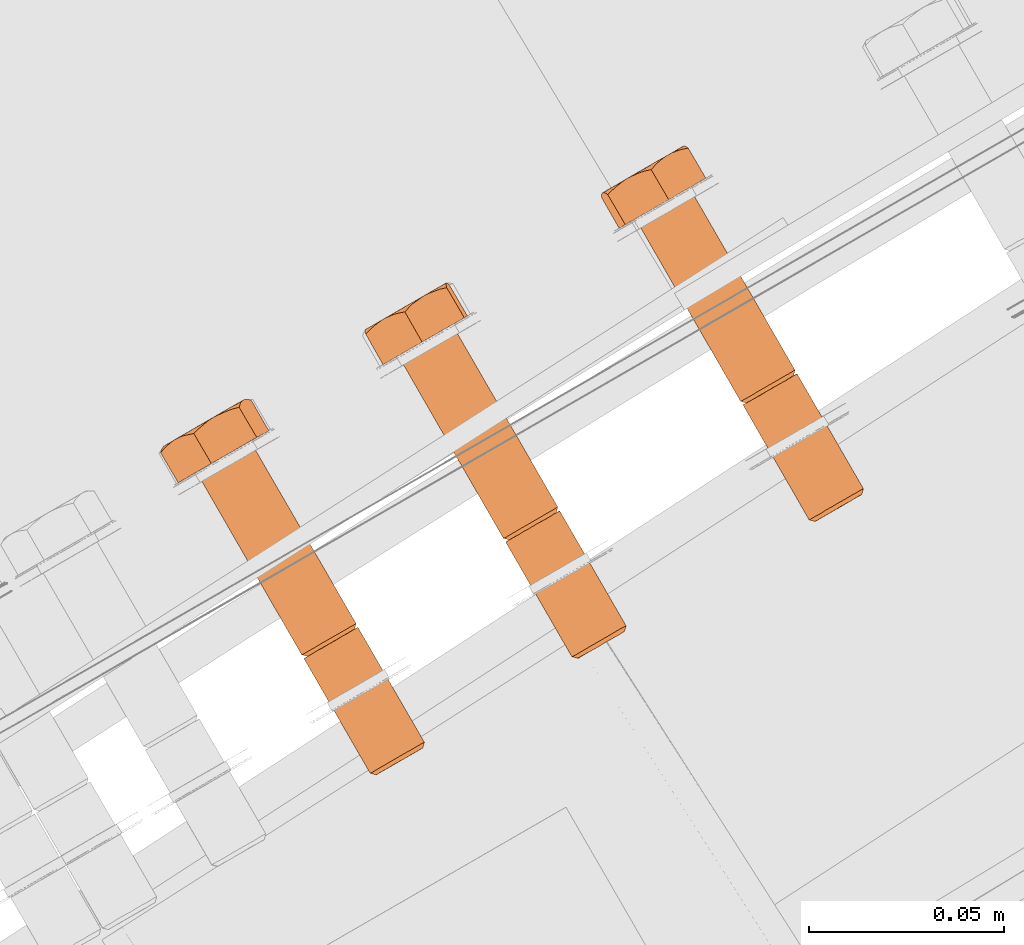
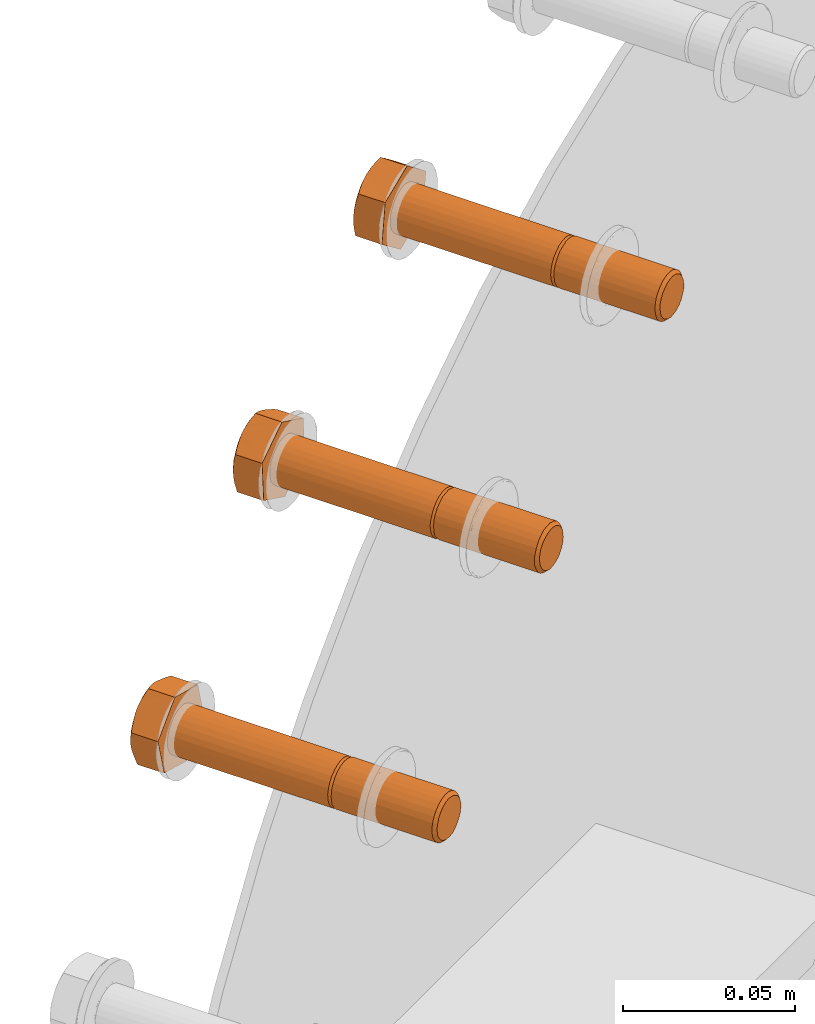
# One storey, part 72 of 126: 3 proxies.
"""IFC2X3 building model written with IfcOpenShell, lengths in millimetres."""

from ifc_helpers import new_model, si_unit, origin, origin_with_axes, place, context, project, spatial, faceted_brep, material, element, save


model = new_model("IFC2X3")

# Units and contexts
context_of_model_1 = context(None, 3, precision=0.1, world=origin())
context_of_model_2 = context(None, 3, precision=0.1, world=origin())
ifc_project = project(units=[si_unit("LENGTHUNIT", "METRE", prefix="MILLI"), si_unit("AREAUNIT", "SQUARE_METRE", prefix="CENTI"), si_unit("VOLUMEUNIT", "CUBIC_METRE", prefix="CENTI"), si_unit("MASSUNIT", "GRAM", prefix="KILO")], contexts=[context_of_model_1, context_of_model_2])

# Site, building, storey
site_placement = place(None, origin_with_axes())
site = spatial("IfcSite", under=ifc_project, at=site_placement, CompositionType="ELEMENT")
building_placement = place(site_placement, origin_with_axes())
building = spatial("IfcBuilding", under=site, at=building_placement, CompositionType="ELEMENT")
storey_placement = place(building_placement, origin_with_axes())
storey = spatial("IfcBuildingStorey", under=building, at=storey_placement, CompositionType="ELEMENT")

# Proxies
ifc_material = material(Name="STAHL")
proxy_1_placement = place(storey_placement, origin_with_axes())
element("IfcBuildingElementProxy", 1, at=proxy_1_placement, inside=storey, material=ifc_material, Name="profile", context=context_of_model_2, shape_type="Brep", body=[
    faceted_brep([(3737.7, 14723.2, 1175.6), (3736.3, 14722.4, 1174.4), (3737.6, 14721.9, 1173.7), (3738.7, 14722.5, 1174.7), (3740.0, 14723.3, 1175.4), (3739.2, 14724.1, 1176.4), (3741.4, 14724.1, 1175.7), (3740.8, 14725.0, 1176.8), (3742.9, 14724.9, 1175.6), (3742.5, 14726.0, 1176.7), (3744.2, 14725.7, 1175.1), (3744.1, 14726.9, 1176.1), (3745.5, 14726.4, 1174.2), (3745.5, 14727.7, 1175.1), (3746.5, 14727.0, 1173.1), (3746.7, 14728.4, 1173.7), (3747.3, 14727.5, 1171.6), (3747.6, 14728.9, 1172.1), (3747.7, 14727.7, 1170.0), (3748.1, 14729.2, 1170.2), (3747.8, 14727.8, 1168.4), (3748.2, 14729.2, 1168.3), (3747.5, 14727.6, 1166.7), (3747.9, 14729.1, 1166.4), (3746.9, 14727.3, 1165.2), (3747.2, 14728.7, 1164.7), (3746.0, 14726.8, 1163.9), (3746.1, 14728.1, 1163.1), (3721.2, 14752.8, 1174.7), (3720.2, 14753.5, 1175.6), (3718.8, 14752.7, 1174.4), (3720.1, 14752.2, 1173.7), (3722.5, 14753.6, 1175.4), (3721.7, 14754.4, 1176.4), (3723.9, 14754.4, 1175.7), (3723.3, 14755.3, 1176.8), (3725.4, 14755.2, 1175.6), (3725.0, 14756.3, 1176.7), (3726.7, 14756.0, 1175.1), (3726.6, 14757.2, 1176.1), (3728.0, 14756.8, 1174.2), (3728.0, 14758.0, 1175.1), (3729.0, 14757.3, 1173.1), (3729.2, 14758.7, 1173.7), (3729.8, 14757.8, 1171.6), (3730.1, 14759.2, 1172.1), (3730.2, 14758.0, 1170.0), (3730.6, 14759.5, 1170.2), (3730.3, 14758.1, 1168.4), (3730.7, 14759.6, 1168.3), (3730.0, 14757.9, 1166.7), (3730.4, 14759.4, 1166.4), (3729.4, 14757.6, 1165.2), (3729.7, 14759.0, 1164.7), (3728.5, 14757.1, 1163.9), (3728.6, 14758.4, 1163.1), (3719.4, 14751.8, 1174.4), (3718.4, 14751.2, 1172.9), (3735.3, 14721.8, 1172.9), (3744.8, 14727.3, 1161.9), (3727.9, 14756.7, 1161.9), (3729.2, 14757.5, 1163.1), (3743.3, 14726.4, 1161.2), (3726.3, 14755.8, 1161.2), (3741.7, 14725.5, 1160.8), (3724.7, 14754.9, 1160.8), (3740.0, 14724.5, 1160.9), (3723.0, 14753.9, 1160.9), (3738.4, 14723.6, 1161.5), (3721.4, 14753.0, 1161.5), (3737.0, 14722.8, 1162.5), (3720.0, 14752.2, 1162.5), (3735.8, 14722.1, 1163.9), (3718.8, 14751.5, 1163.9), (3734.9, 14721.6, 1165.5), (3718.0, 14751.0, 1165.5), (3734.4, 14721.3, 1167.3), (3717.5, 14750.7, 1167.3), (3734.3, 14721.3, 1169.3), (3717.4, 14750.6, 1169.3), (3734.6, 14721.4, 1171.2), (3717.7, 14750.8, 1171.2), (3693.2, 14800.2, 1175.6), (3691.9, 14799.4, 1174.4), (3694.7, 14801.1, 1176.4), (3696.4, 14802.0, 1176.8), (3698.0, 14803.0, 1176.7), (3699.6, 14803.9, 1176.1), (3701.1, 14804.7, 1175.1), (3702.2, 14805.4, 1173.7), (3703.1, 14805.9, 1172.1), (3703.6, 14806.2, 1170.2), (3703.7, 14806.2, 1168.3), (3703.4, 14806.1, 1166.4), (3702.7, 14805.7, 1164.7), (3701.7, 14805.1, 1163.1), (3717.8, 14752.1, 1172.9), (3690.9, 14798.8, 1172.9), (3690.2, 14798.4, 1171.2), (3717.1, 14751.7, 1171.2), (3727.3, 14757.6, 1161.9), (3700.4, 14804.3, 1161.9), (3725.8, 14756.7, 1161.2), (3698.8, 14803.4, 1161.2), (3724.2, 14755.8, 1160.8), (3697.2, 14802.5, 1160.8), (3722.5, 14754.8, 1160.9), (3695.5, 14801.5, 1160.9), (3720.9, 14753.9, 1161.5), (3693.9, 14800.6, 1161.5), (3719.5, 14753.1, 1162.5), (3692.5, 14799.8, 1162.5), (3718.3, 14752.4, 1163.9), (3691.3, 14799.1, 1163.9), (3717.4, 14751.9, 1165.5), (3690.5, 14798.6, 1165.5), (3716.9, 14751.6, 1167.3), (3690.0, 14798.3, 1167.3), (3716.8, 14751.6, 1169.3), (3689.9, 14798.3, 1169.3), (3685.2, 14795.6, 1172.4), (3688.3, 14797.4, 1159.0), (3699.9, 14804.0, 1155.4), (3708.4, 14808.9, 1165.2), (3705.3, 14807.2, 1178.6), (3693.7, 14800.5, 1182.2), (3683.8, 14805.1, 1159.0), (3685.3, 14806.5, 1158.5), (3686.7, 14807.7, 1158.0), (3687.9, 14808.6, 1157.6), (3689.1, 14809.4, 1157.2), (3690.7, 14810.2, 1156.7), (3692.4, 14810.9, 1156.2), (3693.9, 14811.4, 1155.8), (3695.4, 14811.8, 1155.4), (3690.9, 14810.4, 1156.8), (3692.7, 14811.4, 1156.8), (3694.5, 14812.5, 1157.2), (3696.2, 14813.4, 1157.9), (3697.7, 14814.4, 1159.0), (3698.2, 14814.6, 1159.2), (3697.4, 14813.9, 1158.2), (3696.4, 14812.9, 1156.8), (3699.1, 14815.2, 1160.3), (3681.7, 14805.1, 1165.7), (3682.4, 14805.5, 1163.7), (3683.3, 14806.0, 1161.9), (3684.4, 14806.7, 1160.3), (3685.8, 14807.5, 1159.0), (3687.4, 14808.4, 1157.9), (3683.3, 14805.2, 1160.5), (3682.8, 14805.3, 1162.0), (3682.2, 14805.3, 1163.9), (3680.7, 14803.3, 1172.4), (3681.5, 14804.2, 1173.5), (3682.3, 14805.0, 1174.6), (3683.3, 14805.9, 1175.9), (3684.4, 14806.7, 1177.3), (3683.3, 14806.0, 1175.7), (3682.4, 14805.5, 1173.9), (3681.7, 14805.1, 1171.9), (3681.4, 14804.9, 1169.8), (3681.4, 14804.9, 1167.7), (3681.4, 14804.9, 1167.1), (3681.2, 14804.5, 1168.6), (3680.9, 14804.0, 1170.5), (3700.3, 14815.8, 1161.6), (3701.6, 14816.2, 1163.0), (3702.7, 14816.5, 1164.1), (3703.9, 14816.7, 1165.2), (3703.2, 14816.9, 1167.1), (3702.6, 14816.9, 1169.0), (3702.2, 14816.9, 1170.4), (3701.8, 14816.7, 1171.9), (3701.4, 14816.4, 1173.7), (3701.1, 14815.9, 1175.5), (3701.0, 14815.5, 1177.0), (3700.8, 14814.9, 1178.6), (3685.4, 14807.2, 1178.4), (3686.4, 14807.6, 1179.4), (3687.8, 14807.9, 1180.8), (3689.2, 14808.2, 1182.2), (3690.3, 14809.3, 1181.8), (3691.5, 14810.3, 1181.4), (3692.9, 14811.5, 1180.9), (3694.5, 14812.5, 1180.4), (3692.7, 14811.4, 1180.7), (3690.9, 14810.4, 1180.7), (3689.1, 14809.4, 1180.4), (3687.4, 14808.4, 1179.7), (3685.8, 14807.5, 1178.6), (3696.2, 14813.4, 1179.7), (3697.1, 14813.7, 1179.6), (3698.9, 14814.4, 1179.1), (3701.2, 14816.4, 1173.9), (3700.3, 14815.8, 1175.7), (3699.1, 14815.2, 1177.3), (3697.7, 14814.4, 1178.6), (3695.8, 14813.1, 1180.0), (3700.3, 14815.8, 1161.9), (3701.2, 14816.4, 1163.7), (3701.8, 14816.7, 1165.7), (3702.1, 14816.9, 1167.7), (3702.1, 14816.9, 1169.8), (3720.7, 14752.6, 1175.6), (3719.2, 14751.7, 1172.4), (3718.6, 14751.3, 1170.8), (3718.3, 14751.2, 1169.2), (3718.4, 14751.2, 1167.5), (3718.8, 14751.5, 1165.9), (3719.6, 14751.9, 1164.5), (3720.6, 14752.5, 1163.3), (3721.8, 14753.2, 1162.5), (3723.2, 14754.0, 1162.0), (3724.6, 14754.8, 1161.9), (3726.1, 14755.7, 1162.2), (3727.4, 14756.4, 1162.9), (3722.2, 14753.4, 1176.4), (3723.9, 14754.4, 1176.8), (3725.5, 14755.3, 1176.7), (3727.1, 14756.3, 1176.1), (3728.6, 14757.1, 1175.1), (3729.7, 14757.8, 1173.7), (3730.6, 14758.3, 1172.1), (3731.1, 14758.6, 1170.2), (3731.2, 14758.6, 1168.3), (3730.9, 14758.4, 1166.4), (3730.2, 14758.0, 1164.7), (3735.8, 14720.9, 1169.2), (3735.9, 14720.9, 1167.5), (3736.3, 14721.2, 1165.9), (3737.1, 14721.6, 1164.5), (3738.1, 14722.2, 1163.3), (3739.3, 14722.9, 1162.5), (3740.7, 14723.7, 1162.0), (3742.1, 14724.5, 1161.9), (3743.6, 14725.3, 1162.2), (3744.9, 14726.1, 1162.9), (3736.7, 14721.4, 1172.4), (3736.1, 14721.0, 1170.8)], [[[0, 1, 2, 3]], [[4, 5, 0, 3]], [[6, 7, 5, 4]], [[8, 9, 7, 6]], [[10, 11, 9, 8]], [[12, 13, 11, 10]], [[14, 15, 13, 12]], [[16, 17, 15, 14]], [[18, 19, 17, 16]], [[20, 21, 19, 18]], [[22, 23, 21, 20]], [[24, 25, 23, 22]], [[26, 27, 25, 24]], [[28, 29, 30, 31]], [[32, 33, 29, 28]], [[34, 35, 33, 32]], [[36, 37, 35, 34]], [[38, 39, 37, 36]], [[40, 41, 39, 38]], [[42, 43, 41, 40]], [[44, 45, 43, 42]], [[46, 47, 45, 44]], [[48, 49, 47, 46]], [[50, 51, 49, 48]], [[52, 53, 51, 50]], [[54, 55, 53, 52]], [[1, 56, 57, 58]], [[59, 60, 61, 27]], [[62, 63, 60, 59]], [[64, 65, 63, 62]], [[66, 67, 65, 64]], [[68, 69, 67, 66]], [[70, 71, 69, 68]], [[72, 73, 71, 70]], [[74, 75, 73, 72]], [[76, 77, 75, 74]], [[78, 79, 77, 76]], [[80, 81, 79, 78]], [[58, 57, 81, 80]], [[29, 82, 83, 30]], [[29, 33, 84, 82]], [[33, 35, 85, 84]], [[35, 37, 86, 85]], [[37, 39, 87, 86]], [[39, 41, 88, 87]], [[41, 43, 89, 88]], [[43, 45, 90, 89]], [[45, 47, 91, 90]], [[47, 49, 92, 91]], [[49, 51, 93, 92]], [[51, 53, 94, 93]], [[55, 95, 94, 53]], [[96, 97, 98, 99]], [[30, 83, 97, 96]], [[55, 100, 101, 95]], [[102, 103, 101, 100]], [[104, 105, 103, 102]], [[106, 107, 105, 104]], [[108, 109, 107, 106]], [[110, 111, 109, 108]], [[112, 113, 111, 110]], [[114, 115, 113, 112]], [[116, 117, 115, 114]], [[118, 119, 117, 116]], [[99, 98, 119, 118]], [[120, 121, 122, 123, 124, 125, 86, 87, 88, 89, 90, 91, 92, 93, 94, 95, 101, 103, 105, 107, 109, 111, 113, 115, 117, 119, 98, 97, 83, 82, 84, 85, 86, 125]], [[121, 126, 127, 128, 129, 130, 131, 132, 133, 134, 122]], [[130, 135, 136, 137, 138, 139, 140, 141, 142, 134, 133, 132, 131]], [[143, 140, 139]], [[144, 145, 146, 147, 148, 149, 129, 128, 127, 126, 150, 151, 152]], [[130, 129, 149]], [[153, 154, 155, 156, 157, 158, 159, 160, 161, 162, 163, 164, 165]], [[144, 163, 162]], [[122, 134, 142, 141, 140, 143, 166, 167, 168, 169, 123]], [[124, 123, 169, 170, 171, 172, 173, 174, 175, 176, 177]], [[178, 179, 180, 181, 182, 183, 184, 185, 186, 187, 188, 189, 190]], [[157, 178, 190]], [[191, 192, 193, 177, 176, 175, 174, 173, 194, 195, 196, 197]], [[198, 192, 191]], [[185, 198, 191]], [[143, 199, 200, 201, 202, 203, 172, 171, 170, 169, 168, 167, 166]], [[173, 172, 203]], [[125, 124, 177, 193, 192, 198, 185, 184, 183, 182, 181]], [[120, 125, 181, 180, 179, 178, 157, 156, 155, 154, 153]], [[120, 153, 165, 164, 163, 144, 152, 151, 150, 126, 121]], [[161, 160, 159, 158, 157, 190, 189, 188, 187, 186, 185, 191, 197, 196, 195, 194, 173, 203, 202, 201, 200, 199, 143, 139, 138, 137, 136, 135, 130, 149, 148, 147, 146, 145, 144, 162]], [[79, 81, 57, 56, 204, 28, 31, 205, 206, 207, 208, 209, 210, 211, 212, 213, 214, 215, 216, 54, 52, 50, 48, 46, 44, 42, 40, 38, 36, 34, 32, 28, 204, 217, 218, 219, 220, 221, 222, 223, 224, 225, 226, 227, 61, 60, 63, 65, 67, 69, 71, 73, 75, 77]], [[100, 55, 54, 216]], [[102, 100, 216, 215]], [[104, 102, 215, 214]], [[106, 104, 214, 213]], [[108, 106, 213, 212]], [[110, 108, 212, 211]], [[112, 110, 211, 210]], [[114, 112, 210, 209]], [[116, 114, 209, 208]], [[118, 116, 208, 207]], [[99, 118, 207, 206]], [[96, 99, 206, 205]], [[31, 30, 96, 205]], [[0, 204, 56, 1]], [[0, 5, 217, 204]], [[5, 7, 218, 217]], [[7, 9, 219, 218]], [[9, 11, 220, 219]], [[11, 13, 221, 220]], [[13, 15, 222, 221]], [[15, 17, 223, 222]], [[17, 19, 224, 223]], [[19, 21, 225, 224]], [[21, 23, 226, 225]], [[23, 25, 227, 226]], [[25, 27, 61, 227]], [[228, 229, 230, 231, 232, 233, 234, 235, 236, 237, 26, 24, 22, 20, 18, 16, 14, 12, 10, 8, 6, 4, 3, 2, 238, 239]], [[237, 59, 27, 26]], [[236, 62, 59, 237]], [[235, 64, 62, 236]], [[234, 66, 64, 235]], [[233, 68, 66, 234]], [[232, 70, 68, 233]], [[231, 72, 70, 232]], [[230, 74, 72, 231]], [[229, 76, 74, 230]], [[228, 78, 76, 229]], [[239, 80, 78, 228]], [[238, 58, 80, 239]], [[2, 1, 58, 238]]]),
])
proxy_2_placement = place(storey_placement, origin_with_axes())
element("IfcBuildingElementProxy", 2, at=proxy_2_placement, inside=storey, material=ifc_material, Name="profile", context=context_of_model_2, shape_type="Brep", body=[
    faceted_brep([(3791.4, 14752.9, 1234.9), (3790.5, 14753.7, 1235.9), (3789.0, 14752.8, 1235.0), (3790.1, 14752.2, 1234.1), (3792.1, 14754.6, 1236.3), (3792.8, 14753.7, 1235.3), (3793.8, 14755.6, 1236.3), (3794.2, 14754.6, 1235.2), (3795.4, 14756.5, 1235.8), (3795.6, 14755.4, 1234.8), (3796.9, 14757.4, 1234.9), (3796.9, 14756.1, 1234.0), (3798.1, 14758.1, 1233.6), (3798.0, 14756.7, 1232.9), (3799.0, 14758.6, 1232.0), (3798.8, 14757.2, 1231.5), (3799.6, 14758.9, 1230.2), (3799.2, 14757.5, 1229.9), (3799.8, 14759.0, 1228.3), (3799.4, 14757.6, 1228.3), (3799.6, 14758.9, 1226.4), (3799.2, 14757.5, 1226.6), (3799.0, 14758.6, 1224.6), (3798.7, 14757.2, 1225.1), (3798.0, 14758.0, 1223.0), (3797.8, 14756.7, 1223.7), (3796.7, 14757.3, 1221.7), (3796.7, 14756.0, 1222.6), (3773.9, 14783.2, 1234.9), (3773.0, 14784.0, 1235.9), (3771.5, 14783.1, 1235.0), (3772.6, 14782.5, 1234.1), (3775.3, 14784.1, 1235.3), (3774.6, 14784.9, 1236.3), (3776.7, 14784.9, 1235.2), (3776.3, 14785.9, 1236.3), (3778.1, 14785.7, 1234.8), (3777.9, 14786.8, 1235.8), (3779.4, 14786.4, 1234.0), (3779.4, 14787.7, 1234.9), (3780.5, 14787.0, 1232.9), (3780.6, 14788.4, 1233.6), (3781.3, 14787.5, 1231.5), (3781.5, 14788.9, 1232.0), (3781.7, 14787.8, 1229.9), (3782.1, 14789.3, 1230.2), (3781.9, 14787.9, 1228.3), (3782.3, 14789.4, 1228.3), (3781.7, 14787.8, 1226.6), (3782.1, 14789.2, 1226.4), (3781.2, 14787.5, 1225.1), (3781.5, 14788.9, 1224.6), (3780.3, 14787.0, 1223.7), (3780.5, 14788.3, 1223.0), (3779.2, 14786.3, 1222.6), (3779.2, 14787.6, 1221.7), (3772.1, 14782.2, 1235.0), (3770.8, 14781.5, 1233.8), (3787.8, 14752.1, 1233.8), (3795.2, 14756.4, 1220.9), (3778.3, 14785.8, 1220.9), (3779.8, 14786.6, 1221.7), (3793.6, 14755.5, 1220.4), (3776.6, 14784.8, 1220.4), (3791.9, 14754.5, 1220.5), (3775.0, 14783.9, 1220.5), (3790.3, 14753.6, 1221.0), (3773.4, 14782.9, 1221.0), (3788.8, 14752.7, 1221.9), (3771.9, 14782.1, 1221.9), (3787.6, 14752.0, 1223.2), (3770.7, 14781.4, 1223.2), (3786.7, 14751.5, 1224.8), (3769.7, 14780.9, 1224.8), (3786.1, 14751.2, 1226.6), (3769.2, 14780.5, 1226.6), (3785.9, 14751.1, 1228.5), (3769.0, 14780.4, 1228.5), (3786.2, 14751.2, 1230.4), (3769.2, 14780.6, 1230.4), (3786.8, 14751.5, 1232.2), (3769.8, 14780.9, 1232.2), (3746.0, 14830.7, 1235.9), (3744.6, 14829.8, 1235.0), (3747.7, 14831.6, 1236.3), (3749.3, 14832.6, 1236.3), (3751.0, 14833.5, 1235.8), (3752.4, 14834.4, 1234.9), (3753.7, 14835.1, 1233.6), (3754.6, 14835.6, 1232.0), (3755.2, 14836.0, 1230.2), (3755.3, 14836.1, 1228.3), (3755.1, 14835.9, 1226.4), (3754.5, 14835.6, 1224.6), (3753.5, 14835.0, 1223.0), (3752.3, 14834.3, 1221.7), (3770.3, 14782.4, 1233.8), (3743.3, 14829.1, 1233.8), (3742.3, 14828.5, 1232.2), (3769.3, 14781.8, 1232.2), (3777.7, 14786.7, 1220.9), (3750.8, 14833.4, 1220.9), (3776.1, 14785.8, 1220.4), (3749.1, 14832.5, 1220.4), (3774.4, 14784.8, 1220.5), (3747.5, 14831.5, 1220.5), (3772.8, 14783.9, 1221.0), (3745.9, 14830.6, 1221.0), (3771.3, 14783.0, 1221.9), (3744.4, 14829.7, 1221.9), (3770.1, 14782.3, 1223.2), (3743.2, 14829.0, 1223.2), (3769.2, 14781.8, 1224.8), (3742.2, 14828.5, 1224.8), (3768.6, 14781.5, 1226.6), (3741.7, 14828.2, 1226.6), (3768.4, 14781.4, 1228.5), (3741.5, 14828.1, 1228.5), (3768.7, 14781.5, 1230.4), (3741.7, 14828.2, 1230.4), (3737.6, 14825.8, 1234.5), (3738.4, 14826.3, 1220.7), (3749.2, 14832.5, 1214.6), (3759.2, 14838.3, 1222.3), (3758.4, 14837.8, 1236.1), (3747.6, 14831.6, 1242.2), (3734.0, 14834.0, 1220.7), (3735.3, 14835.4, 1219.8), (3736.6, 14836.5, 1219.0), (3737.7, 14837.3, 1218.3), (3738.8, 14838.1, 1217.6), (3740.3, 14838.8, 1216.8), (3741.9, 14839.5, 1216.0), (3743.3, 14839.9, 1215.3), (3744.7, 14840.2, 1214.6), (3740.5, 14839.0, 1216.9), (3742.3, 14840.1, 1216.5), (3744.1, 14841.1, 1216.4), (3745.9, 14842.1, 1216.7), (3747.6, 14843.1, 1217.4), (3748.1, 14843.4, 1217.6), (3747.1, 14842.6, 1216.7), (3745.9, 14841.5, 1215.7), (3749.2, 14844.0, 1218.4), (3733.7, 14834.3, 1222.3), (3733.4, 14834.6, 1223.8), (3733.2, 14834.7, 1225.7), (3733.0, 14834.7, 1227.6), (3733.3, 14834.9, 1225.5), (3733.9, 14835.2, 1223.6), (3734.8, 14835.7, 1221.7), (3735.9, 14836.4, 1220.1), (3737.3, 14837.2, 1218.7), (3733.2, 14833.6, 1234.5), (3734.1, 14834.6, 1235.4), (3735.1, 14835.5, 1236.3), (3736.3, 14836.5, 1237.3), (3737.6, 14837.4, 1238.4), (3736.2, 14836.6, 1237.1), (3735.0, 14835.9, 1235.5), (3734.1, 14835.3, 1233.7), (3733.4, 14835.0, 1231.8), (3733.1, 14834.8, 1229.7), (3733.0, 14834.4, 1230.6), (3733.0, 14834.1, 1232.5), (3733.0, 14834.6, 1229.1), (3750.6, 14844.8, 1219.5), (3752.1, 14845.3, 1220.5), (3753.4, 14845.7, 1221.4), (3754.7, 14846.0, 1222.3), (3754.3, 14846.4, 1224.3), (3754.1, 14846.6, 1226.2), (3753.9, 14846.7, 1227.7), (3753.8, 14846.7, 1229.2), (3753.7, 14846.6, 1231.1), (3753.7, 14846.3, 1233.0), (3753.8, 14846.0, 1234.5), (3753.9, 14845.5, 1236.1), (3738.8, 14838.0, 1239.2), (3739.9, 14838.5, 1240.1), (3741.5, 14839.0, 1241.1), (3743.2, 14839.3, 1242.2), (3744.2, 14840.4, 1241.5), (3745.2, 14841.4, 1240.8), (3746.6, 14842.4, 1240.0), (3748.0, 14843.4, 1239.2), (3746.3, 14842.4, 1239.9), (3744.5, 14841.4, 1240.3), (3742.7, 14840.3, 1240.4), (3740.9, 14839.3, 1240.1), (3739.2, 14838.3, 1239.4), (3749.2, 14844.0, 1238.5), (3750.5, 14844.5, 1237.8), (3752.1, 14845.1, 1237.0), (3753.5, 14846.5, 1231.2), (3752.9, 14846.2, 1233.2), (3752.0, 14845.7, 1235.1), (3750.9, 14845.1, 1236.7), (3749.6, 14844.3, 1238.1), (3750.6, 14844.9, 1219.7), (3751.8, 14845.6, 1221.3), (3752.7, 14846.1, 1223.1), (3753.4, 14846.5, 1225.0), (3753.7, 14846.7, 1227.1), (3773.5, 14783.1, 1235.9), (3771.5, 14781.9, 1233.1), (3770.6, 14781.4, 1231.7), (3770.1, 14781.1, 1230.2), (3769.9, 14781.0, 1228.5), (3770.1, 14781.1, 1226.8), (3770.6, 14781.3, 1225.3), (3771.4, 14781.8, 1223.9), (3772.4, 14782.4, 1222.8), (3773.7, 14783.1, 1222.0), (3775.1, 14784.0, 1221.5), (3776.5, 14784.8, 1221.5), (3777.9, 14785.6, 1221.9), (3775.2, 14784.0, 1236.3), (3776.8, 14785.0, 1236.3), (3778.5, 14785.9, 1235.8), (3779.9, 14786.7, 1234.9), (3781.2, 14787.5, 1233.6), (3782.1, 14788.0, 1232.0), (3782.7, 14788.3, 1230.2), (3782.8, 14788.4, 1228.3), (3782.6, 14788.3, 1226.4), (3782.0, 14787.9, 1224.6), (3781.0, 14787.4, 1223.0), (3787.4, 14750.7, 1228.5), (3787.6, 14750.7, 1226.8), (3788.1, 14751.0, 1225.3), (3788.9, 14751.5, 1223.9), (3789.9, 14752.1, 1222.8), (3791.2, 14752.8, 1222.0), (3792.6, 14753.6, 1221.5), (3794.0, 14754.5, 1221.5), (3795.4, 14755.3, 1221.9), (3789.0, 14751.6, 1233.1), (3788.1, 14751.1, 1231.7), (3787.6, 14750.8, 1230.2)], [[[0, 1, 2, 3]], [[4, 1, 0, 5]], [[6, 4, 5, 7]], [[8, 6, 7, 9]], [[10, 8, 9, 11]], [[12, 10, 11, 13]], [[14, 12, 13, 15]], [[16, 14, 15, 17]], [[18, 16, 17, 19]], [[20, 18, 19, 21]], [[22, 20, 21, 23]], [[24, 22, 23, 25]], [[26, 24, 25, 27]], [[28, 29, 30, 31]], [[32, 33, 29, 28]], [[34, 35, 33, 32]], [[36, 37, 35, 34]], [[38, 39, 37, 36]], [[40, 41, 39, 38]], [[42, 43, 41, 40]], [[44, 45, 43, 42]], [[46, 47, 45, 44]], [[48, 49, 47, 46]], [[50, 51, 49, 48]], [[52, 53, 51, 50]], [[54, 55, 53, 52]], [[2, 56, 57, 58]], [[59, 60, 61, 26]], [[62, 63, 60, 59]], [[64, 65, 63, 62]], [[66, 67, 65, 64]], [[68, 69, 67, 66]], [[70, 71, 69, 68]], [[72, 73, 71, 70]], [[74, 75, 73, 72]], [[76, 77, 75, 74]], [[78, 79, 77, 76]], [[80, 81, 79, 78]], [[58, 57, 81, 80]], [[30, 29, 82, 83]], [[29, 33, 84, 82]], [[33, 35, 85, 84]], [[35, 37, 86, 85]], [[37, 39, 87, 86]], [[39, 41, 88, 87]], [[41, 43, 89, 88]], [[43, 45, 90, 89]], [[45, 47, 91, 90]], [[47, 49, 92, 91]], [[49, 51, 93, 92]], [[51, 53, 94, 93]], [[55, 95, 94, 53]], [[96, 97, 98, 99]], [[30, 83, 97, 96]], [[55, 100, 101, 95]], [[102, 103, 101, 100]], [[104, 105, 103, 102]], [[106, 107, 105, 104]], [[108, 109, 107, 106]], [[110, 111, 109, 108]], [[112, 113, 111, 110]], [[114, 115, 113, 112]], [[116, 117, 115, 114]], [[118, 119, 117, 116]], [[99, 98, 119, 118]], [[120, 121, 122, 123, 124, 125, 86, 87, 88, 89, 90, 91, 92, 93, 94, 95, 101, 103, 105, 107, 109, 111, 113, 115, 117, 119, 98, 97, 83, 82, 84, 85, 86, 125]], [[121, 126, 127, 128, 129, 130, 131, 132, 133, 134, 122]], [[130, 135, 136, 137, 138, 139, 140, 141, 142, 134, 133, 132, 131]], [[143, 140, 139]], [[126, 144, 145, 146, 147, 148, 149, 150, 151, 152, 129, 128, 127]], [[130, 129, 152]], [[153, 154, 155, 156, 157, 158, 159, 160, 161, 162, 163, 164]], [[165, 163, 162]], [[147, 165, 162]], [[122, 134, 142, 141, 140, 143, 166, 167, 168, 169, 123]], [[124, 123, 169, 170, 171, 172, 173, 174, 175, 176, 177]], [[178, 179, 180, 181, 182, 183, 184, 185, 186, 187, 188, 189, 190]], [[157, 178, 190]], [[191, 192, 193, 177, 176, 175, 174, 173, 194, 195, 196, 197, 198]], [[185, 191, 198]], [[143, 199, 200, 201, 202, 203, 171, 170, 169, 168, 167, 166]], [[172, 171, 203]], [[173, 172, 203]], [[125, 124, 177, 193, 192, 191, 185, 184, 183, 182, 181]], [[120, 125, 181, 180, 179, 178, 157, 156, 155, 154, 153]], [[120, 153, 164, 163, 165, 147, 146, 145, 144, 126, 121]], [[147, 162, 161, 160, 159, 158, 157, 190, 189, 188, 187, 186, 185, 198, 197, 196, 195, 194, 173, 203, 202, 201, 200, 199, 143, 139, 138, 137, 136, 135, 130, 152, 151, 150, 149, 148]], [[77, 79, 81, 57, 56, 204, 28, 31, 205, 206, 207, 208, 209, 210, 211, 212, 213, 214, 215, 216, 54, 52, 50, 48, 46, 44, 42, 40, 38, 36, 34, 32, 28, 204, 217, 218, 219, 220, 221, 222, 223, 224, 225, 226, 227, 61, 60, 63, 65, 67, 69, 71, 73, 75]], [[100, 55, 54, 216]], [[102, 100, 216, 215]], [[104, 102, 215, 214]], [[106, 104, 214, 213]], [[108, 106, 213, 212]], [[110, 108, 212, 211]], [[112, 110, 211, 210]], [[114, 112, 210, 209]], [[116, 114, 209, 208]], [[118, 116, 208, 207]], [[99, 118, 207, 206]], [[96, 99, 206, 205]], [[31, 30, 96, 205]], [[1, 204, 56, 2]], [[1, 4, 217, 204]], [[4, 6, 218, 217]], [[6, 8, 219, 218]], [[8, 10, 220, 219]], [[10, 12, 221, 220]], [[12, 14, 222, 221]], [[14, 16, 223, 222]], [[16, 18, 224, 223]], [[18, 20, 225, 224]], [[20, 22, 226, 225]], [[22, 24, 227, 226]], [[24, 26, 61, 227]], [[228, 229, 230, 231, 232, 233, 234, 235, 236, 27, 25, 23, 21, 19, 17, 15, 13, 11, 9, 7, 5, 0, 3, 237, 238, 239]], [[236, 59, 26, 27]], [[235, 62, 59, 236]], [[234, 64, 62, 235]], [[233, 66, 64, 234]], [[232, 68, 66, 233]], [[231, 70, 68, 232]], [[230, 72, 70, 231]], [[229, 74, 72, 230]], [[228, 76, 74, 229]], [[239, 78, 76, 228]], [[238, 80, 78, 239]], [[237, 58, 80, 238]], [[3, 2, 58, 237]]]),
])
proxy_3_placement = place(storey_placement, origin_with_axes())
element("IfcBuildingElementProxy", 3, at=proxy_3_placement, inside=storey, material=ifc_material, Name="profile", context=context_of_model_2, shape_type="Brep", body=[
    faceted_brep([(3852.5, 14789.5, 1283.1), (3850.9, 14788.6, 1282.6), (3851.8, 14787.8, 1281.6), (3853.2, 14788.6, 1282.1), (3854.2, 14790.5, 1283.2), (3854.6, 14789.5, 1282.1), (3855.8, 14791.4, 1282.8), (3856.1, 14790.3, 1281.8), (3857.3, 14792.3, 1281.9), (3857.4, 14791.0, 1281.0), (3858.6, 14793.0, 1280.7), (3858.5, 14791.7, 1280.0), (3859.6, 14793.6, 1279.2), (3859.3, 14792.2, 1278.6), (3860.2, 14793.9, 1277.4), (3859.9, 14792.5, 1277.1), (3860.5, 14794.1, 1275.5), (3860.1, 14792.6, 1275.4), (3860.3, 14794.0, 1273.5), (3860.0, 14792.5, 1273.8), (3859.8, 14793.7, 1271.7), (3859.5, 14792.3, 1272.2), (3858.9, 14793.2, 1270.1), (3858.7, 14791.8, 1270.8), (3857.7, 14792.5, 1268.8), (3857.7, 14791.2, 1269.7), (3856.2, 14791.6, 1267.8), (3856.4, 14790.5, 1268.8), (3835.7, 14818.9, 1282.1), (3835.0, 14819.8, 1283.1), (3833.4, 14818.9, 1282.6), (3834.3, 14818.1, 1281.6), (3836.7, 14820.8, 1283.2), (3837.1, 14819.8, 1282.1), (3838.3, 14821.7, 1282.8), (3838.6, 14820.6, 1281.8), (3839.8, 14822.6, 1281.9), (3839.9, 14821.3, 1281.0), (3841.1, 14823.3, 1280.7), (3841.0, 14822.0, 1280.0), (3842.1, 14823.9, 1279.2), (3841.8, 14822.5, 1278.6), (3842.7, 14824.3, 1277.4), (3842.4, 14822.8, 1277.1), (3843.0, 14824.4, 1275.5), (3842.6, 14822.9, 1275.4), (3842.8, 14824.3, 1273.5), (3842.5, 14822.9, 1273.8), (3842.3, 14824.0, 1271.7), (3842.0, 14822.6, 1272.2), (3841.4, 14823.5, 1270.1), (3841.2, 14822.1, 1270.8), (3840.2, 14822.8, 1268.8), (3840.2, 14821.5, 1269.7), (3838.7, 14821.9, 1267.8), (3838.9, 14820.8, 1268.8), (3834.0, 14817.9, 1282.6), (3832.5, 14817.1, 1281.7), (3849.5, 14787.7, 1281.7), (3854.6, 14790.7, 1267.3), (3837.6, 14820.1, 1267.3), (3839.3, 14821.0, 1267.8), (3852.9, 14789.7, 1267.3), (3836.0, 14819.1, 1267.3), (3851.3, 14788.8, 1267.7), (3834.3, 14818.2, 1267.7), (3849.8, 14787.9, 1268.5), (3832.8, 14817.3, 1268.5), (3848.5, 14787.2, 1269.7), (3831.6, 14816.6, 1269.7), (3847.5, 14786.6, 1271.3), (3830.6, 14816.0, 1271.3), (3846.9, 14786.2, 1273.1), (3829.9, 14815.6, 1273.1), (3846.6, 14786.1, 1275.0), (3829.7, 14815.5, 1275.0), (3846.8, 14786.2, 1276.9), (3829.8, 14815.6, 1276.9), (3847.3, 14786.5, 1278.7), (3830.4, 14815.9, 1278.7), (3848.2, 14787.0, 1280.3), (3831.3, 14816.4, 1280.3), (3811.8, 14868.6, 1267.8), (3813.2, 14869.5, 1268.8), (3814.4, 14870.2, 1270.1), (3808.1, 14866.5, 1283.1), (3806.5, 14865.6, 1282.6), (3809.7, 14867.5, 1283.2), (3811.4, 14868.4, 1282.8), (3812.9, 14869.3, 1281.9), (3814.2, 14870.0, 1280.7), (3815.1, 14870.6, 1279.2), (3815.8, 14871.0, 1277.4), (3816.0, 14871.1, 1275.5), (3815.9, 14871.0, 1273.5), (3815.3, 14870.7, 1271.7), (3837.1, 14821.0, 1267.3), (3810.1, 14867.7, 1267.3), (3835.4, 14820.0, 1267.3), (3808.5, 14866.7, 1267.3), (3833.8, 14819.1, 1267.7), (3806.8, 14865.8, 1267.7), (3832.3, 14818.2, 1268.5), (3805.3, 14864.9, 1268.5), (3831.0, 14817.5, 1269.7), (3804.1, 14864.2, 1269.7), (3830.0, 14816.9, 1271.3), (3803.1, 14863.6, 1271.3), (3829.4, 14816.6, 1273.1), (3802.4, 14863.2, 1273.1), (3829.1, 14816.4, 1275.0), (3802.2, 14863.1, 1275.0), (3829.3, 14816.5, 1276.9), (3802.3, 14863.2, 1276.9), (3829.8, 14816.8, 1278.7), (3802.9, 14863.5, 1278.7), (3830.7, 14817.3, 1280.3), (3803.8, 14864.0, 1280.3), (3832.0, 14818.0, 1281.7), (3805.0, 14864.7, 1281.7), (3798.0, 14860.7, 1269.9), (3807.5, 14866.2, 1261.5), (3818.6, 14872.6, 1266.8), (3820.2, 14873.5, 1280.5), (3810.7, 14868.0, 1289.0), (3799.6, 14861.6, 1283.7), (3793.6, 14868.4, 1269.9), (3794.7, 14869.7, 1268.7), (3795.8, 14870.7, 1267.5), (3796.8, 14871.5, 1266.6), (3797.8, 14872.1, 1265.7), (3799.1, 14872.8, 1264.6), (3800.5, 14873.3, 1263.4), (3801.8, 14873.7, 1262.5), (3803.1, 14873.9, 1261.5), (3799.3, 14873.0, 1264.6), (3801.0, 14874.0, 1263.8), (3802.7, 14875.0, 1263.3), (3804.6, 14876.0, 1263.2), (3806.4, 14877.1, 1263.5), (3806.9, 14877.3, 1263.6), (3805.8, 14876.5, 1263.0), (3804.4, 14875.3, 1262.2), (3808.1, 14878.1, 1264.1), (3793.5, 14868.9, 1271.5), (3793.5, 14869.3, 1273.0), (3793.6, 14869.6, 1274.9), (3793.8, 14869.8, 1276.8), (3793.7, 14869.8, 1274.7), (3794.0, 14869.9, 1272.6), (3794.5, 14870.2, 1270.6), (3795.3, 14870.7, 1268.8), (3796.4, 14871.3, 1267.1), (3795.1, 14869.3, 1283.7), (3796.2, 14870.4, 1284.3), (3797.3, 14871.4, 1284.9), (3798.7, 14872.5, 1285.6), (3800.1, 14873.5, 1286.3), (3798.5, 14872.5, 1285.3), (3797.1, 14871.7, 1284.1), (3795.9, 14871.0, 1282.5), (3794.9, 14870.4, 1280.8), (3794.2, 14870.0, 1278.8), (3794.3, 14869.8, 1279.8), (3794.6, 14869.6, 1281.7), (3794.0, 14869.9, 1278.3), (3809.6, 14878.9, 1264.9), (3811.3, 14879.5, 1265.6), (3812.7, 14880.0, 1266.2), (3814.2, 14880.3, 1266.8), (3814.1, 14880.9, 1268.8), (3814.2, 14881.3, 1270.7), (3814.3, 14881.6, 1272.2), (3814.4, 14881.7, 1273.7), (3814.7, 14881.8, 1275.5), (3815.0, 14881.7, 1277.4), (3815.3, 14881.5, 1278.9), (3815.7, 14881.2, 1280.5), (3801.4, 14874.1, 1286.9), (3802.7, 14874.7, 1287.5), (3804.4, 14875.3, 1288.2), (3806.2, 14875.7, 1289.0), (3807.1, 14876.7, 1288.0), (3808.0, 14877.6, 1287.0), (3809.2, 14878.6, 1285.9), (3810.4, 14879.4, 1284.7), (3808.9, 14878.5, 1285.9), (3807.2, 14877.6, 1286.7), (3805.5, 14876.5, 1287.1), (3803.7, 14875.5, 1287.2), (3801.9, 14874.5, 1286.9), (3811.5, 14880.0, 1283.8), (3812.6, 14880.4, 1282.9), (3814.1, 14880.9, 1281.7), (3814.5, 14881.8, 1275.7), (3814.3, 14881.6, 1277.8), (3813.7, 14881.3, 1279.8), (3812.9, 14880.8, 1281.7), (3811.8, 14880.2, 1283.3), (3809.7, 14879.0, 1265.1), (3811.1, 14879.8, 1266.4), (3812.4, 14880.5, 1267.9), (3813.3, 14881.1, 1269.7), (3814.0, 14881.5, 1271.6), (3835.6, 14818.9, 1283.1), (3837.2, 14819.8, 1283.2), (3838.9, 14820.8, 1282.8), (3840.4, 14821.6, 1281.9), (3841.7, 14822.4, 1280.7), (3842.6, 14823.0, 1279.2), (3843.3, 14823.3, 1277.4), (3843.5, 14823.5, 1275.5), (3843.4, 14823.4, 1273.5), (3842.8, 14823.1, 1271.7), (3841.9, 14822.5, 1270.1), (3840.7, 14821.8, 1268.8), (3831.4, 14816.5, 1271.8), (3832.2, 14816.9, 1270.5), (3833.4, 14817.6, 1269.4), (3834.7, 14818.3, 1268.7), (3836.1, 14819.2, 1268.3), (3837.5, 14820.0, 1268.4), (3833.1, 14817.4, 1280.8), (3832.0, 14816.8, 1279.7), (3831.2, 14816.4, 1278.3), (3830.7, 14816.1, 1276.7), (3830.6, 14816.0, 1275.0), (3830.8, 14816.1, 1273.4), (3848.1, 14785.7, 1275.0), (3848.3, 14785.8, 1273.4), (3848.9, 14786.1, 1271.8), (3849.7, 14786.6, 1270.5), (3850.9, 14787.3, 1269.4), (3852.2, 14788.0, 1268.7), (3853.6, 14788.8, 1268.3), (3855.0, 14789.7, 1268.4), (3850.6, 14787.1, 1280.8), (3849.5, 14786.5, 1279.7), (3848.7, 14786.0, 1278.3), (3848.2, 14785.8, 1276.7)], [[[0, 1, 2, 3]], [[4, 0, 3, 5]], [[6, 4, 5, 7]], [[8, 6, 7, 9]], [[10, 8, 9, 11]], [[12, 10, 11, 13]], [[14, 12, 13, 15]], [[16, 14, 15, 17]], [[18, 16, 17, 19]], [[20, 18, 19, 21]], [[22, 20, 21, 23]], [[24, 22, 23, 25]], [[26, 24, 25, 27]], [[28, 29, 30, 31]], [[32, 29, 28, 33]], [[34, 32, 33, 35]], [[36, 34, 35, 37]], [[38, 36, 37, 39]], [[40, 38, 39, 41]], [[42, 40, 41, 43]], [[44, 42, 43, 45]], [[46, 44, 45, 47]], [[48, 46, 47, 49]], [[50, 48, 49, 51]], [[52, 50, 51, 53]], [[54, 52, 53, 55]], [[1, 56, 57, 58]], [[59, 60, 61, 26]], [[62, 63, 60, 59]], [[64, 65, 63, 62]], [[66, 67, 65, 64]], [[68, 69, 67, 66]], [[70, 71, 69, 68]], [[72, 73, 71, 70]], [[74, 75, 73, 72]], [[76, 77, 75, 74]], [[78, 79, 77, 76]], [[80, 81, 79, 78]], [[58, 57, 81, 80]], [[52, 54, 82, 83]], [[52, 83, 84, 50]], [[30, 29, 85, 86]], [[32, 87, 85, 29]], [[34, 88, 87, 32]], [[36, 89, 88, 34]], [[38, 90, 89, 36]], [[40, 91, 90, 38]], [[42, 92, 91, 40]], [[44, 93, 92, 42]], [[46, 94, 93, 44]], [[48, 95, 94, 46]], [[50, 84, 95, 48]], [[54, 96, 97, 82]], [[96, 98, 99, 97]], [[98, 100, 101, 99]], [[100, 102, 103, 101]], [[102, 104, 105, 103]], [[104, 106, 107, 105]], [[106, 108, 109, 107]], [[108, 110, 111, 109]], [[110, 112, 113, 111]], [[112, 114, 115, 113]], [[114, 116, 117, 115]], [[116, 118, 119, 117]], [[30, 86, 119, 118]], [[120, 121, 122, 123, 124, 89, 90, 91, 92, 93, 94, 95, 84, 83, 82, 97, 99, 101, 103, 105, 107, 109, 111, 113, 115, 117, 119, 86, 85, 87, 88, 89, 124, 125]], [[120, 126, 127, 128, 129, 130, 131, 132, 133, 134, 121]], [[130, 135, 136, 137, 138, 139, 140, 141, 142, 134, 133, 132, 131]], [[143, 140, 139]], [[126, 144, 145, 146, 147, 148, 149, 150, 151, 152, 129, 128, 127]], [[130, 129, 152]], [[153, 154, 155, 156, 157, 158, 159, 160, 161, 162, 163, 164]], [[165, 163, 162]], [[147, 165, 162]], [[121, 134, 142, 141, 140, 143, 166, 167, 168, 169, 122]], [[122, 169, 170, 171, 172, 173, 174, 175, 176, 177, 123]], [[178, 179, 180, 181, 182, 183, 184, 185, 186, 187, 188, 189, 190]], [[157, 178, 190]], [[191, 192, 193, 177, 176, 175, 174, 173, 194, 195, 196, 197, 198]], [[185, 191, 198]], [[143, 199, 200, 201, 202, 203, 171, 170, 169, 168, 167, 166]], [[172, 171, 203]], [[173, 172, 203]], [[124, 123, 177, 193, 192, 191, 185, 184, 183, 182, 181]], [[125, 124, 181, 180, 179, 178, 157, 156, 155, 154, 153]], [[120, 125, 153, 164, 163, 165, 147, 146, 145, 144, 126]], [[148, 147, 162, 161, 160, 159, 158, 157, 190, 189, 188, 187, 186, 185, 198, 197, 196, 195, 194, 173, 203, 202, 201, 200, 199, 143, 139, 138, 137, 136, 135, 130, 152, 151, 150, 149]], [[75, 77, 79, 81, 57, 56, 204, 205, 206, 207, 208, 209, 210, 211, 212, 213, 214, 215, 61, 60, 63, 65, 67, 69, 216, 217, 218, 219, 220, 221, 55, 53, 51, 49, 47, 45, 43, 41, 39, 37, 35, 33, 28, 31, 222, 223, 224, 225, 226, 227, 216, 69, 71, 73]], [[221, 96, 54, 55]], [[220, 98, 96, 221]], [[219, 100, 98, 220]], [[218, 102, 100, 219]], [[217, 104, 102, 218]], [[216, 106, 104, 217]], [[227, 108, 106, 216]], [[226, 110, 108, 227]], [[225, 112, 110, 226]], [[224, 114, 112, 225]], [[223, 116, 114, 224]], [[222, 118, 116, 223]], [[31, 30, 118, 222]], [[26, 61, 215, 24]], [[1, 0, 204, 56]], [[4, 205, 204, 0]], [[6, 206, 205, 4]], [[8, 207, 206, 6]], [[10, 208, 207, 8]], [[12, 209, 208, 10]], [[14, 210, 209, 12]], [[16, 211, 210, 14]], [[18, 212, 211, 16]], [[20, 213, 212, 18]], [[22, 214, 213, 20]], [[24, 215, 214, 22]], [[228, 229, 230, 231, 232, 233, 234, 235, 27, 25, 23, 21, 19, 17, 15, 13, 11, 9, 7, 5, 3, 2, 236, 237, 238, 239]], [[59, 26, 27, 235]], [[234, 62, 59, 235]], [[233, 64, 62, 234]], [[232, 66, 64, 233]], [[231, 68, 66, 232]], [[230, 70, 68, 231]], [[229, 72, 70, 230]], [[228, 74, 72, 229]], [[239, 76, 74, 228]], [[238, 78, 76, 239]], [[237, 80, 78, 238]], [[236, 58, 80, 237]], [[2, 1, 58, 236]]]),
])

save(model, "model.ifc")
